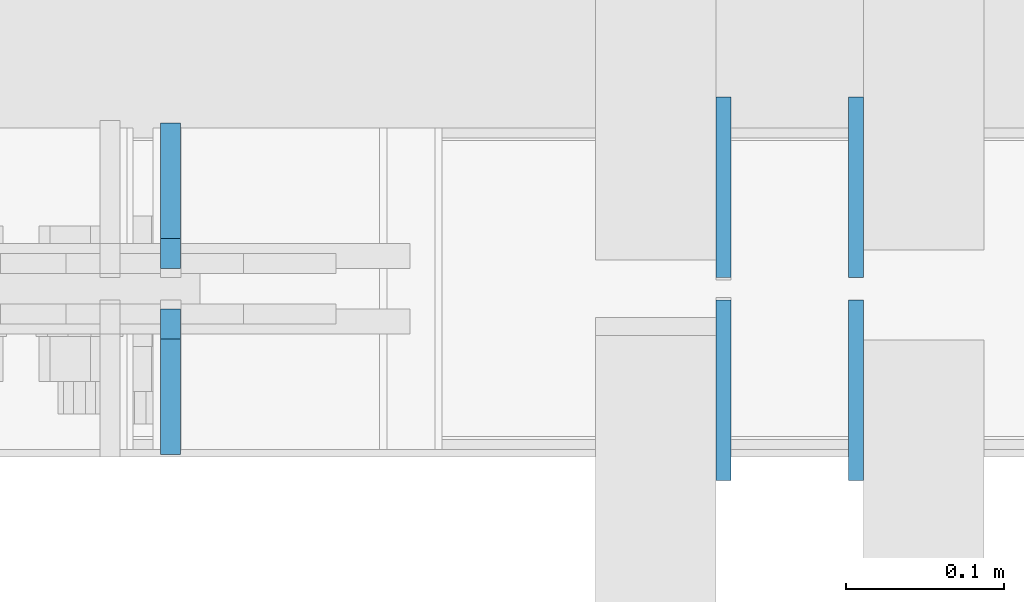
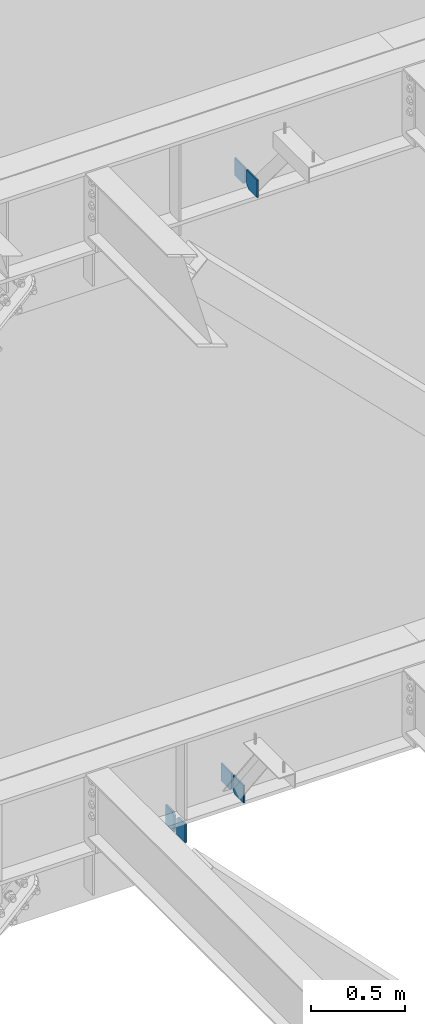
# One storey, part 522 of 1179: 6 columns, 2 elements without a shape of their own.
"""IFC2X3 building model written with IfcOpenShell, lengths in millimetres."""

from ifc_helpers import new_model, si_unit, frame, origin_with_axes, place, context, subcontext, project, spatial, faceted_brep, material, type_object, element, aggregate, save


model = new_model("IFC2X3")

# Units and contexts
model_context = context("Model", 3, precision=1e-05, world=origin_with_axes())
body_context = subcontext(model_context, "Body", "Model", "MODEL_VIEW")
ifc_project = project(units=[si_unit("LENGTHUNIT", "METRE", prefix="MILLI"), si_unit("AREAUNIT", "SQUARE_METRE"), si_unit("VOLUMEUNIT", "CUBIC_METRE"), si_unit("MASSUNIT", "GRAM", prefix="KILO"), si_unit("TIMEUNIT", "SECOND"), si_unit("PLANEANGLEUNIT", "RADIAN"), si_unit("SOLIDANGLEUNIT", "STERADIAN"), si_unit("THERMODYNAMICTEMPERATUREUNIT", "DEGREE_CELSIUS"), si_unit("LUMINOUSINTENSITYUNIT", "LUMEN")], contexts=[model_context])

# Site, building, storey
site_placement = place(None, origin_with_axes())
site = spatial("IfcSite", under=ifc_project, at=site_placement, CompositionType="ELEMENT")
building_placement = place(site_placement, origin_with_axes())
building = spatial("IfcBuilding", under=site, at=building_placement, Name="Undefined", CompositionType="ELEMENT")
storey_placement = place(building_placement, origin_with_axes())
storey = spatial("IfcBuildingStorey", under=building, at=storey_placement, Name="Undefined", CompositionType="ELEMENT", Elevation=0.0)

# Assembly, columns
assembly_1_placement = place(storey_placement, origin_with_axes())
assembly_1 = element("IfcElementAssembly", 1, at=assembly_1_placement, inside=storey, Name="BEAM", AssemblyPlace="NOTDEFINED", PredefinedType="RIGID_FRAME")
ifc_material_1 = material(Name="STEEL/A36")
column_type_1 = type_object("IfcColumnType", PredefinedType="NOTDEFINED")
column_1_placement = place(assembly_1_placement, frame((5359.16728739681, 41263.09375, 7488.2375), z_axis=(0.0, -1.0, 0.0), x_axis=(0.0, 0.0, 1.0)))
column_1 = element("IfcColumn", 2, at=column_1_placement, type_object=column_type_1, material=ifc_material_1, Name="PLATE", context=body_context, shape_type="Brep", body=[
    faceted_brep([(22.2250000000004, 4.76250000000073, 57.1500000000015), (0.0, 4.76250000000073, 34.9249999999993), (0.0, -4.76250000000073, 34.9249999999993), (22.2250000000004, -4.76250000000073, 57.1500000000015), (114.300000000001, 4.76250000000073, 57.1500000000015), (114.300000000001, 4.76250000000073, -57.1500000000015), (0.0, 4.76250000000073, -57.1500000000015), (114.300000000001, -4.76250000000073, 57.1500000000015), (0.0, -4.76250000000073, -57.1500000000015), (114.300000000001, -4.76250000000073, -57.1500000000015)], [[[0, 1, 2, 3]], [[4, 5, 6, 1, 0]], [[7, 4, 0, 3]], [[8, 9, 7, 3, 2]], [[8, 6, 5, 9]], [[7, 9, 5, 4]], [[6, 8, 2, 1]]]),
])
column_2_placement = place(assembly_1_placement, frame((5359.16728739681, 41134.50625, 7488.2375), z_axis=(0.0, 1.0, 0.0), x_axis=(0.0, 0.0, 1.0)))
column_2 = element("IfcColumn", 3, at=column_2_placement, type_object=column_type_1, material=ifc_material_1, Name="PLATE", context=body_context, shape_type="Brep", body=[
    faceted_brep([(22.2250000000004, 4.76250000000073, 57.1500000000015), (0.0, 4.76250000000073, 34.9249999999993), (0.0, -4.76250000000073, 34.9249999999993), (22.2250000000004, -4.76250000000073, 57.1500000000015), (114.300000000001, 4.76250000000073, 57.1500000000015), (114.300000000001, 4.76250000000073, -57.1500000000015), (0.0, 4.76250000000073, -57.1500000000015), (114.300000000001, -4.76250000000073, 57.1500000000015), (0.0, -4.76250000000073, -57.1500000000015), (114.300000000001, -4.76250000000073, -57.1500000000015)], [[[0, 1, 2, 3]], [[4, 5, 6, 1, 0]], [[7, 4, 0, 3]], [[8, 9, 7, 3, 2]], [[8, 6, 5, 9]], [[7, 9, 5, 4]], [[6, 8, 2, 1]]]),
])
aggregate(assembly_1, [column_1, column_2])

assembly_2_placement = place(storey_placement, origin_with_axes())
assembly_2 = element("IfcElementAssembly", 4, at=assembly_2_placement, inside=storey, Name="BEAM", AssemblyPlace="NOTDEFINED", PredefinedType="RIGID_FRAME")
column_3_placement = place(assembly_2_placement, frame((5275.2625, 41263.09375, 3576.6375), z_axis=(0.0, -1.0, 0.0), x_axis=(0.0, 0.0, 1.0)))
column_3 = element("IfcColumn", 5, at=column_3_placement, type_object=column_type_1, material=ifc_material_1, Name="PLATE", context=body_context, shape_type="Brep", body=[
    faceted_brep([(19.0500000000002, 4.76250000000073, 57.1500000000015), (0.0, 4.76250000000073, 38.0999999999985), (0.0, -4.76250000000073, 38.0999999999985), (19.0500000000002, -4.76250000000073, 57.1500000000015), (114.300000000001, 4.76250000000073, 57.1500000000015), (114.300000000001, 4.76250000000073, -57.1500000000015), (0.0, 4.76250000000073, -57.1500000000015), (114.300000000001, -4.76250000000073, 57.1500000000015), (0.0, -4.76250000000073, -57.1500000000015), (114.300000000001, -4.76250000000073, -57.1500000000015)], [[[0, 1, 2, 3]], [[4, 5, 6, 1, 0]], [[7, 4, 0, 3]], [[8, 9, 7, 3, 2]], [[8, 6, 5, 9]], [[7, 9, 5, 4]], [[6, 8, 2, 1]]]),
])
column_4_placement = place(assembly_2_placement, frame((5275.2625, 41134.50625, 3576.6375), z_axis=(0.0, 1.0, 0.0), x_axis=(0.0, 0.0, 1.0)))
column_4 = element("IfcColumn", 6, at=column_4_placement, type_object=column_type_1, material=ifc_material_1, Name="PLATE", context=body_context, shape_type="Brep", body=[
    faceted_brep([(19.0500000000002, 4.76250000000073, 57.1500000000015), (0.0, 4.76250000000073, 38.0999999999985), (0.0, -4.76250000000073, 38.0999999999985), (19.0500000000002, -4.76250000000073, 57.1500000000015), (114.300000000001, 4.76250000000073, 57.1500000000015), (114.300000000001, 4.76250000000073, -57.1500000000015), (0.0, 4.76250000000073, -57.1500000000015), (114.300000000001, -4.76250000000073, 57.1500000000015), (0.0, -4.76250000000073, -57.1500000000015), (114.300000000001, -4.76250000000073, -57.1500000000015)], [[[0, 1, 2, 3]], [[4, 5, 6, 1, 0]], [[7, 4, 0, 3]], [[8, 9, 7, 3, 2]], [[8, 6, 5, 9]], [[7, 9, 5, 4]], [[6, 8, 2, 1]]]),
])
ifc_material_2 = material(Name="STEEL/A572-GR.50")
column_type_2 = type_object("IfcColumnType", PredefinedType="NOTDEFINED")
column_5_placement = place(assembly_2_placement, frame((4925.57053979219, 41257.5375, 3431.26298117093), z_axis=(0.0, -1.0, 0.0), x_axis=(0.0, 0.0, 1.0)))
column_5 = element("IfcColumn", 7, at=column_5_placement, type_object=column_type_2, material=ifc_material_2, Name="PLATE", context=body_context, shape_type="Brep", body=[
    faceted_brep([(102.512018829071, -6.35000000000036, 46.0374999999985), (121.562018829071, -6.35000000000036, 26.9875000000029), (121.562018829071, 6.35000000000036, 26.9875000000029), (102.512018829071, 6.35000000000036, 46.0374999999985), (121.562018829071, 6.35000000000036, -46.0374999999985), (0.0, 6.35000000000036, -46.0374999999985), (0.0, 6.35000000000036, 46.0374999999985), (0.0, -6.35000000000036, 46.0374999999985), (0.0, -6.35000000000036, -46.0374999999985), (121.562018829071, -6.35000000000036, -46.0374999999985)], [[[0, 1, 2, 3]], [[4, 5, 6, 3, 2]], [[6, 7, 0, 3]], [[7, 8, 9, 1, 0]], [[8, 5, 4, 9]], [[9, 4, 2, 1]], [[8, 7, 6, 5]]]),
])
column_6_placement = place(assembly_2_placement, frame((4925.57053979219, 41140.0625, 3431.26298117093), z_axis=(0.0, 1.0, 0.0), x_axis=(0.0, 0.0, 1.0)))
column_6 = element("IfcColumn", 8, at=column_6_placement, type_object=column_type_2, material=ifc_material_2, Name="PLATE", context=body_context, shape_type="Brep", body=[
    faceted_brep([(102.512018829071, -6.35000000000036, 46.0374999999985), (121.562018829071, -6.35000000000036, 26.9875000000029), (121.562018829071, 6.35000000000036, 26.9875000000029), (102.512018829071, 6.35000000000036, 46.0374999999985), (121.562018829071, 6.35000000000036, -46.0374999999985), (0.0, 6.35000000000036, -46.0374999999985), (0.0, 6.35000000000036, 46.0374999999985), (0.0, -6.35000000000036, 46.0374999999985), (0.0, -6.35000000000036, -46.0374999999985), (121.562018829071, -6.35000000000036, -46.0374999999985)], [[[0, 1, 2, 3]], [[4, 5, 6, 3, 2]], [[6, 7, 0, 3]], [[7, 8, 9, 1, 0]], [[8, 5, 4, 9]], [[9, 4, 2, 1]], [[8, 7, 6, 5]]]),
])
aggregate(assembly_2, [column_5, column_6, column_3, column_4])

save(model, "model.ifc")
